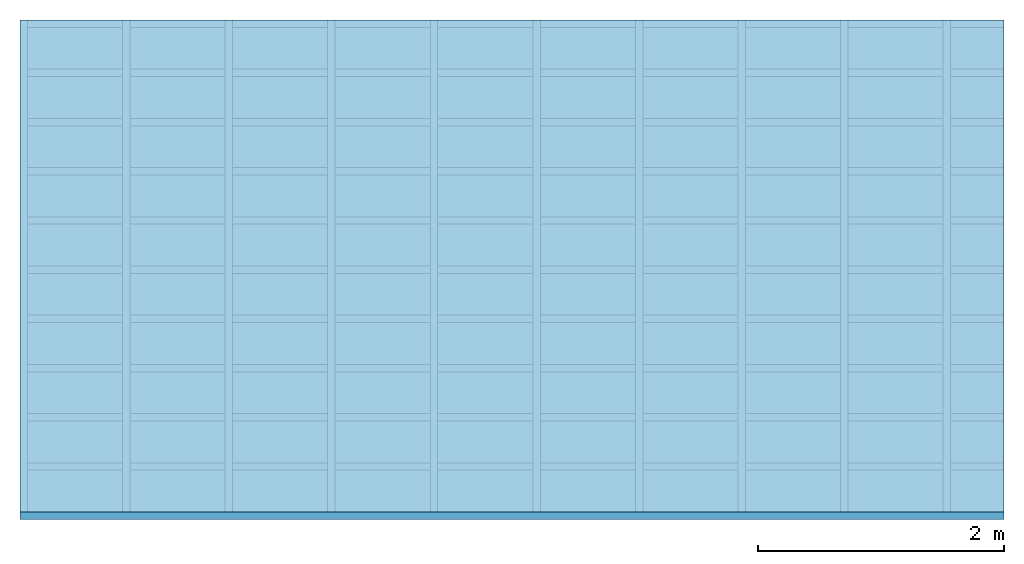
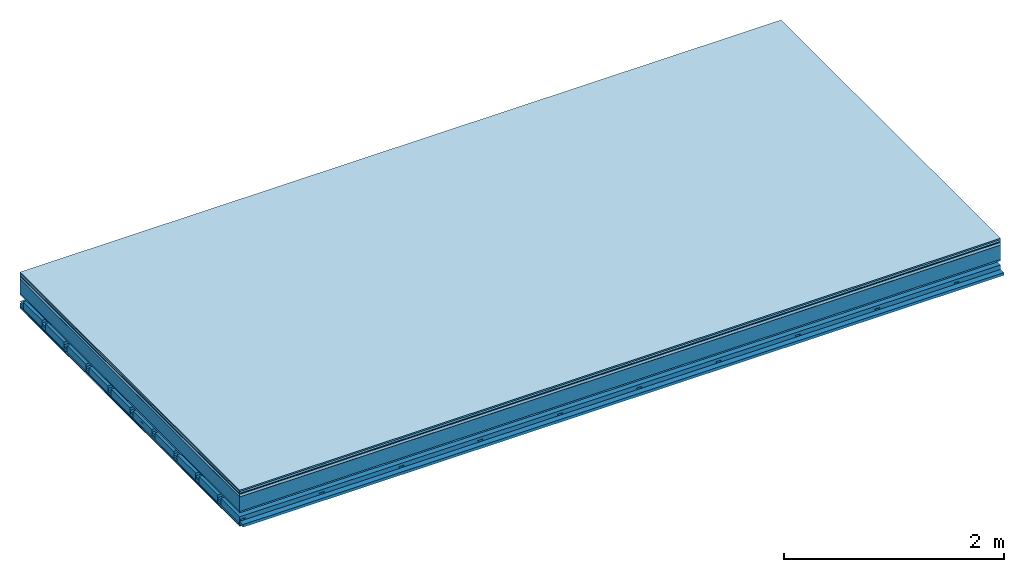
# One storey: 9 plates, 4 members, 1 element without a shape of its own.
"""IFC4 building model written with IfcOpenShell, lengths in metres."""

from ifc_helpers import new_model, si_unit, derived_unit, direction, frame, frame_2d, origin, origin_with_axes, place, context, project, spatial, polyline, rectangle, outline, extrude, material, layer, layer_set, type_object, element, aggregate, save


model = new_model("IFC4")

# Units and contexts
plan_context = context("Plan", 3, precision=1e-05, world=origin(), true_north=direction((0.0, 1.0)))
model_context = context("Model", 3, precision=1e-05, world=origin(), true_north=direction((0.0, 1.0)))
ifc_project = project(units=[si_unit("LENGTHUNIT", "METRE"), derived_unit("SOUNDPRESSUREUNIT", [(si_unit("PRESSUREUNIT", "PASCAL", prefix="MICRO"), 0)]), si_unit("ENERGYUNIT", "JOULE", prefix="MEGA"), si_unit("MASSUNIT", "GRAM", prefix="KILO"), derived_unit("THERMALTRANSMITTANCEUNIT", [(si_unit("POWERUNIT", "WATT"), 1), (si_unit("AREAUNIT", "SQUARE_METRE"), -1), (si_unit("THERMODYNAMICTEMPERATUREUNIT", "KELVIN"), -1)]), derived_unit("AREADENSITYUNIT", [(si_unit("MASSUNIT", "GRAM", prefix="KILO"), 1), (si_unit("AREAUNIT", "SQUARE_METRE"), -1)]), derived_unit("USERDEFINED", [(si_unit("ENERGYUNIT", "JOULE", prefix="MEGA"), 1), (si_unit("AREAUNIT", "SQUARE_METRE"), -1)])], contexts=[plan_context, model_context])

# Site, building, storey
site = spatial("IfcSite", under=ifc_project)
building_placement = place(None, origin())
building = spatial("IfcBuilding", under=site, at=building_placement)
storey_placement = place(building_placement, origin())
storey = spatial("IfcBuildingStorey", under=building, at=storey_placement)

# Slab, members, plates
ifc_material_1 = material(Category="11.013")
ifc_layer_1 = layer(ifc_material_1, 0.015, Name="Flooring")
ifc_material_2 = material(Category="03.007")
ifc_layer_2 = layer(ifc_material_2, 0.02, Name="On-material")
ifc_material_3 = material(Name="Wood fiber generic product", Category="10.009")
ifc_layer_3 = layer(ifc_material_3, 0.01, Name="Impact sound insulation")
ifc_material_4 = material(Name="with broken")
ifc_layer_4 = layer(ifc_material_4, 0.03, Name="on Supporting structure")
ifc_material_5 = material(Name="protection", Category="09.007")
ifc_layer_5 = layer(ifc_material_5, 0.0005, Name="Sub-floor")
ifc_material_6 = material(Name="no composite action")
ifc_layer_6 = layer(ifc_material_6, 0.0, Name="Bond")
ifc_layer_7 = layer(None, 0.16, Name="Supporting structure")
ifc_material_7 = material(Name="of the art")
ifc_layer_8 = layer(ifc_material_7, 0.0, Name="Bond")
ifc_layer_9 = layer(ifc_material_2, 0.015, Name="Lower layer 1")
ifc_layer_10 = layer(None, 0.095, Name="Coupling")
ifc_layer_11 = layer(None, 0.03, Name="Battens / profiles")
ifc_material_8 = material(Name="Plasterboard type A", Category="03.008")
ifc_layer_12 = layer(ifc_material_8, 0.0125, Name="Ceiling covering 1st layer")
ifc_layer_13 = layer(ifc_material_8, 0.0125, Name="Ceiling covering layer 2")
ifc_material_9 = material(Category="04.001")
ifc_layer_14 = layer(ifc_material_9, 0.003, Name="Surface / treatment")
ifc_layer_set = layer_set([ifc_layer_1, ifc_layer_2, ifc_layer_3, ifc_layer_4, ifc_layer_5, ifc_layer_6, ifc_layer_7, ifc_layer_8, ifc_layer_9, ifc_layer_10, ifc_layer_11, ifc_layer_12, ifc_layer_13, ifc_layer_14])
slab_type = type_object("IfcSlabType", Name="A2125", PredefinedType="NOTDEFINED", material=ifc_layer_set)
slab_placement = place(None, frame((0.0, 0.0, 0.0), z_axis=(0.0, 0.0, -1.0), x_axis=(1.0, 0.0, 0.0)))
slab = element("IfcSlab", 1, at=slab_placement, inside=storey, type_object=slab_type, material=ifc_layer_set, Name="Slab #1")
ifc_material_10 = material(Name="Solid timber panel")
member_1_placement = place(slab_placement, origin())
member_1 = element("IfcMember", 2, at=member_1_placement, material=ifc_material_10, Name="Supporting structure", context=plan_context, shape_type="SweptSolid", body=[
    extrude(rectangle(XDim=1.0, YDim=0.16, at=frame_2d((0.5, 0.08), x_axis=(1.0, 0.0))), frame((0.0, 4.0, 0.0755), z_axis=(0.0, -1.0, 0.0), x_axis=(1.0, 0.0, 0.0)), (0.0, 0.0, 1.0), 4.0),
    extrude(rectangle(XDim=1.0, YDim=0.16, at=frame_2d((0.5, 0.08), x_axis=(1.0, 0.0))), frame((1.0, 4.0, 0.0755), z_axis=(0.0, -1.0, 0.0), x_axis=(1.0, 0.0, 0.0)), (0.0, 0.0, 1.0), 4.0),
    extrude(rectangle(XDim=1.0, YDim=0.16, at=frame_2d((0.5, 0.08), x_axis=(1.0, 0.0))), frame((2.0, 4.0, 0.0755), z_axis=(0.0, -1.0, 0.0), x_axis=(1.0, 0.0, 0.0)), (0.0, 0.0, 1.0), 4.0),
    extrude(rectangle(XDim=1.0, YDim=0.16, at=frame_2d((0.5, 0.08), x_axis=(1.0, 0.0))), frame((3.0, 4.0, 0.0755), z_axis=(0.0, -1.0, 0.0), x_axis=(1.0, 0.0, 0.0)), (0.0, 0.0, 1.0), 4.0),
    extrude(rectangle(XDim=1.0, YDim=0.16, at=frame_2d((0.5, 0.08), x_axis=(1.0, 0.0))), frame((4.0, 4.0, 0.0755), z_axis=(0.0, -1.0, 0.0), x_axis=(1.0, 0.0, 0.0)), (0.0, 0.0, 1.0), 4.0),
    extrude(rectangle(XDim=1.0, YDim=0.16, at=frame_2d((0.5, 0.08), x_axis=(1.0, 0.0))), frame((5.0, 4.0, 0.0755), z_axis=(0.0, -1.0, 0.0), x_axis=(1.0, 0.0, 0.0)), (0.0, 0.0, 1.0), 4.0),
    extrude(rectangle(XDim=1.0, YDim=0.16, at=frame_2d((0.5, 0.08), x_axis=(1.0, 0.0))), frame((6.0, 4.0, 0.0755), z_axis=(0.0, -1.0, 0.0), x_axis=(1.0, 0.0, 0.0)), (0.0, 0.0, 1.0), 4.0),
    extrude(rectangle(XDim=1.0, YDim=0.16, at=frame_2d((0.5, 0.08), x_axis=(1.0, 0.0))), frame((7.0, 4.0, 0.0755), z_axis=(0.0, -1.0, 0.0), x_axis=(1.0, 0.0, 0.0)), (0.0, 0.0, 1.0), 4.0),
])
ifc_material_11 = material()
member_2_placement = place(slab_placement, origin())
member_2 = element("IfcMember", 3, at=member_2_placement, material=ifc_material_11, Name="Coupling", context=plan_context, shape_type="SweptSolid", body=[
    extrude(outline(polyline([(0.0, 0.0), (0.06, 0.0), (0.04, 0.02), (0.02, 0.02), (0.0, 0.0)])), frame((0.0, 4.0, 0.3255), z_axis=(0.0, -1.0, 0.0), x_axis=(1.0, 0.0, 0.0)), (0.0, 0.0, 1.0), 4.0),
    extrude(outline(polyline([(0.0, 0.0), (0.06, 0.0), (0.04, 0.02), (0.02, 0.02), (0.0, 0.0)])), frame((0.834, 4.0, 0.3255), z_axis=(0.0, -1.0, 0.0), x_axis=(1.0, 0.0, 0.0)), (0.0, 0.0, 1.0), 4.0),
    extrude(outline(polyline([(0.0, 0.0), (0.06, 0.0), (0.04, 0.02), (0.02, 0.02), (0.0, 0.0)])), frame((1.668, 4.0, 0.3255), z_axis=(0.0, -1.0, 0.0), x_axis=(1.0, 0.0, 0.0)), (0.0, 0.0, 1.0), 4.0),
    extrude(outline(polyline([(0.0, 0.0), (0.06, 0.0), (0.04, 0.02), (0.02, 0.02), (0.0, 0.0)])), frame((2.502, 4.0, 0.3255), z_axis=(0.0, -1.0, 0.0), x_axis=(1.0, 0.0, 0.0)), (0.0, 0.0, 1.0), 4.0),
    extrude(outline(polyline([(0.0, 0.0), (0.06, 0.0), (0.04, 0.02), (0.02, 0.02), (0.0, 0.0)])), frame((3.336, 4.0, 0.3255), z_axis=(0.0, -1.0, 0.0), x_axis=(1.0, 0.0, 0.0)), (0.0, 0.0, 1.0), 4.0),
    extrude(outline(polyline([(0.0, 0.0), (0.06, 0.0), (0.04, 0.02), (0.02, 0.02), (0.0, 0.0)])), frame((4.17, 4.0, 0.3255), z_axis=(0.0, -1.0, 0.0), x_axis=(1.0, 0.0, 0.0)), (0.0, 0.0, 1.0), 4.0),
    extrude(outline(polyline([(0.0, 0.0), (0.06, 0.0), (0.04, 0.02), (0.02, 0.02), (0.0, 0.0)])), frame((5.004, 4.0, 0.3255), z_axis=(0.0, -1.0, 0.0), x_axis=(1.0, 0.0, 0.0)), (0.0, 0.0, 1.0), 4.0),
    extrude(outline(polyline([(0.0, 0.0), (0.06, 0.0), (0.04, 0.02), (0.02, 0.02), (0.0, 0.0)])), frame((5.838, 4.0, 0.3255), z_axis=(0.0, -1.0, 0.0), x_axis=(1.0, 0.0, 0.0)), (0.0, 0.0, 1.0), 4.0),
    extrude(outline(polyline([(0.0, 0.0), (0.06, 0.0), (0.04, 0.02), (0.02, 0.02), (0.0, 0.0)])), frame((6.672, 4.0, 0.3255), z_axis=(0.0, -1.0, 0.0), x_axis=(1.0, 0.0, 0.0)), (0.0, 0.0, 1.0), 4.0),
    extrude(outline(polyline([(0.0, 0.0), (0.06, 0.0), (0.04, 0.02), (0.02, 0.02), (0.0, 0.0)])), frame((7.506, 4.0, 0.3255), z_axis=(0.0, -1.0, 0.0), x_axis=(1.0, 0.0, 0.0)), (0.0, 0.0, 1.0), 4.0),
])
member_3_placement = place(slab_placement, origin())
member_3 = element("IfcMember", 4, at=member_3_placement, material=ifc_material_11, Name="Battens / profiles", context=plan_context, shape_type="SweptSolid", body=[
    extrude(rectangle(XDim=0.06, YDim=0.03, at=frame_2d((0.03, 0.015), x_axis=(1.0, 0.0))), frame((0.0, 0.0, 0.3455), z_axis=(1.0, 0.0, 0.0), x_axis=(0.0, 1.0, 0.0)), (0.0, 0.0, 1.0), 8.0),
    extrude(rectangle(XDim=0.06, YDim=0.03, at=frame_2d((0.03, 0.015), x_axis=(1.0, 0.0))), frame((0.0, 0.4, 0.3455), z_axis=(1.0, 0.0, 0.0), x_axis=(0.0, 1.0, 0.0)), (0.0, 0.0, 1.0), 8.0),
    extrude(rectangle(XDim=0.06, YDim=0.03, at=frame_2d((0.03, 0.015), x_axis=(1.0, 0.0))), frame((0.0, 0.8, 0.3455), z_axis=(1.0, 0.0, 0.0), x_axis=(0.0, 1.0, 0.0)), (0.0, 0.0, 1.0), 8.0),
    extrude(rectangle(XDim=0.06, YDim=0.03, at=frame_2d((0.03, 0.015), x_axis=(1.0, 0.0))), frame((0.0, 1.2, 0.3455), z_axis=(1.0, 0.0, 0.0), x_axis=(0.0, 1.0, 0.0)), (0.0, 0.0, 1.0), 8.0),
    extrude(rectangle(XDim=0.06, YDim=0.03, at=frame_2d((0.03, 0.015), x_axis=(1.0, 0.0))), frame((0.0, 1.6, 0.3455), z_axis=(1.0, 0.0, 0.0), x_axis=(0.0, 1.0, 0.0)), (0.0, 0.0, 1.0), 8.0),
    extrude(rectangle(XDim=0.06, YDim=0.03, at=frame_2d((0.03, 0.015), x_axis=(1.0, 0.0))), frame((0.0, 2.0, 0.3455), z_axis=(1.0, 0.0, 0.0), x_axis=(0.0, 1.0, 0.0)), (0.0, 0.0, 1.0), 8.0),
    extrude(rectangle(XDim=0.06, YDim=0.03, at=frame_2d((0.03, 0.015), x_axis=(1.0, 0.0))), frame((0.0, 2.4, 0.3455), z_axis=(1.0, 0.0, 0.0), x_axis=(0.0, 1.0, 0.0)), (0.0, 0.0, 1.0), 8.0),
    extrude(rectangle(XDim=0.06, YDim=0.03, at=frame_2d((0.03, 0.015), x_axis=(1.0, 0.0))), frame((0.0, 2.8, 0.3455), z_axis=(1.0, 0.0, 0.0), x_axis=(0.0, 1.0, 0.0)), (0.0, 0.0, 1.0), 8.0),
    extrude(rectangle(XDim=0.06, YDim=0.03, at=frame_2d((0.03, 0.015), x_axis=(1.0, 0.0))), frame((0.0, 3.2, 0.3455), z_axis=(1.0, 0.0, 0.0), x_axis=(0.0, 1.0, 0.0)), (0.0, 0.0, 1.0), 8.0),
    extrude(rectangle(XDim=0.06, YDim=0.03, at=frame_2d((0.03, 0.015), x_axis=(1.0, 0.0))), frame((0.0, 3.6, 0.3455), z_axis=(1.0, 0.0, 0.0), x_axis=(0.0, 1.0, 0.0)), (0.0, 0.0, 1.0), 8.0),
    extrude(rectangle(XDim=0.06, YDim=0.03, at=frame_2d((0.03, 0.015), x_axis=(1.0, 0.0))), frame((0.0, 4.0, 0.3455), z_axis=(1.0, 0.0, 0.0), x_axis=(0.0, 1.0, 0.0)), (0.0, 0.0, 1.0), 8.0),
])
ifc_material_12 = material()
member_4_placement = place(slab_placement, origin())
member_4 = element("IfcMember", 5, at=member_4_placement, material=ifc_material_12, Name="Cavity", context=plan_context, shape_type="SweptSolid", body=[
    extrude(rectangle(XDim=0.34, YDim=0.08, at=frame_2d((0.17, 0.04), x_axis=(1.0, 0.0))), frame((0.0, 0.06, 0.2955), z_axis=(1.0, 0.0, 0.0), x_axis=(0.0, 1.0, 0.0)), (0.0, 0.0, 1.0), 8.0),
    extrude(rectangle(XDim=0.34, YDim=0.08, at=frame_2d((0.17, 0.04), x_axis=(1.0, 0.0))), frame((0.0, 0.46, 0.2955), z_axis=(1.0, 0.0, 0.0), x_axis=(0.0, 1.0, 0.0)), (0.0, 0.0, 1.0), 8.0),
    extrude(rectangle(XDim=0.34, YDim=0.08, at=frame_2d((0.17, 0.04), x_axis=(1.0, 0.0))), frame((0.0, 0.86, 0.2955), z_axis=(1.0, 0.0, 0.0), x_axis=(0.0, 1.0, 0.0)), (0.0, 0.0, 1.0), 8.0),
    extrude(rectangle(XDim=0.34, YDim=0.08, at=frame_2d((0.17, 0.04), x_axis=(1.0, 0.0))), frame((0.0, 1.26, 0.2955), z_axis=(1.0, 0.0, 0.0), x_axis=(0.0, 1.0, 0.0)), (0.0, 0.0, 1.0), 8.0),
    extrude(rectangle(XDim=0.34, YDim=0.08, at=frame_2d((0.17, 0.04), x_axis=(1.0, 0.0))), frame((0.0, 1.66, 0.2955), z_axis=(1.0, 0.0, 0.0), x_axis=(0.0, 1.0, 0.0)), (0.0, 0.0, 1.0), 8.0),
    extrude(rectangle(XDim=0.34, YDim=0.08, at=frame_2d((0.17, 0.04), x_axis=(1.0, 0.0))), frame((0.0, 2.06, 0.2955), z_axis=(1.0, 0.0, 0.0), x_axis=(0.0, 1.0, 0.0)), (0.0, 0.0, 1.0), 8.0),
    extrude(rectangle(XDim=0.34, YDim=0.08, at=frame_2d((0.17, 0.04), x_axis=(1.0, 0.0))), frame((0.0, 2.46, 0.2955), z_axis=(1.0, 0.0, 0.0), x_axis=(0.0, 1.0, 0.0)), (0.0, 0.0, 1.0), 8.0),
    extrude(rectangle(XDim=0.34, YDim=0.08, at=frame_2d((0.17, 0.04), x_axis=(1.0, 0.0))), frame((0.0, 2.86, 0.2955), z_axis=(1.0, 0.0, 0.0), x_axis=(0.0, 1.0, 0.0)), (0.0, 0.0, 1.0), 8.0),
    extrude(rectangle(XDim=0.34, YDim=0.08, at=frame_2d((0.17, 0.04), x_axis=(1.0, 0.0))), frame((0.0, 3.26, 0.2955), z_axis=(1.0, 0.0, 0.0), x_axis=(0.0, 1.0, 0.0)), (0.0, 0.0, 1.0), 8.0),
    extrude(rectangle(XDim=0.34, YDim=0.08, at=frame_2d((0.17, 0.04), x_axis=(1.0, 0.0))), frame((0.0, 3.66, 0.2955), z_axis=(1.0, 0.0, 0.0), x_axis=(0.0, 1.0, 0.0)), (0.0, 0.0, 1.0), 8.0),
])
plate_1_placement = place(slab_placement, origin())
plate_1 = element("IfcPlate", 6, at=plate_1_placement, material=ifc_material_1, Name="Flooring", context=plan_context, shape_type="SweptSolid", body=[
    extrude(rectangle(XDim=8.0, YDim=4.0, at=frame_2d((4.0, 2.0), x_axis=(1.0, 0.0))), origin_with_axes(), (0.0, 0.0, 1.0), 0.015),
])
plate_2_placement = place(slab_placement, origin())
plate_2 = element("IfcPlate", 7, at=plate_2_placement, material=ifc_material_2, Name="On-material", context=plan_context, shape_type="SweptSolid", body=[
    extrude(rectangle(XDim=8.0, YDim=4.0, at=frame_2d((4.0, 2.0), x_axis=(1.0, 0.0))), frame((0.0, 0.0, 0.015), z_axis=(0.0, 0.0, 1.0), x_axis=(1.0, 0.0, 0.0)), (0.0, 0.0, 1.0), 0.02),
])
plate_3_placement = place(slab_placement, origin())
plate_3 = element("IfcPlate", 8, at=plate_3_placement, material=ifc_material_3, Name="Impact sound insulation", context=plan_context, shape_type="SweptSolid", body=[
    extrude(rectangle(XDim=8.0, YDim=4.0, at=frame_2d((4.0, 2.0), x_axis=(1.0, 0.0))), frame((0.0, 0.0, 0.035), z_axis=(0.0, 0.0, 1.0), x_axis=(1.0, 0.0, 0.0)), (0.0, 0.0, 1.0), 0.01),
])
plate_4_placement = place(slab_placement, origin())
plate_4 = element("IfcPlate", 9, at=plate_4_placement, material=ifc_material_4, Name="on Supporting structure", context=plan_context, shape_type="SweptSolid", body=[
    extrude(rectangle(XDim=8.0, YDim=4.0, at=frame_2d((4.0, 2.0), x_axis=(1.0, 0.0))), frame((0.0, 0.0, 0.045), z_axis=(0.0, 0.0, 1.0), x_axis=(1.0, 0.0, 0.0)), (0.0, 0.0, 1.0), 0.03),
])
plate_5_placement = place(slab_placement, origin())
plate_5 = element("IfcPlate", 10, at=plate_5_placement, material=ifc_material_5, Name="Sub-floor", context=plan_context, shape_type="SweptSolid", body=[
    extrude(rectangle(XDim=8.0, YDim=4.0, at=frame_2d((4.0, 2.0), x_axis=(1.0, 0.0))), frame((0.0, 0.0, 0.075), z_axis=(0.0, 0.0, 1.0), x_axis=(1.0, 0.0, 0.0)), (0.0, 0.0, 1.0), 0.0005),
])
plate_6_placement = place(slab_placement, origin())
plate_6 = element("IfcPlate", 11, at=plate_6_placement, material=ifc_material_2, Name="Lower layer 1", context=plan_context, shape_type="SweptSolid", body=[
    extrude(rectangle(XDim=8.0, YDim=4.0, at=frame_2d((4.0, 2.0), x_axis=(1.0, 0.0))), frame((0.0, 0.0, 0.2355), z_axis=(0.0, 0.0, 1.0), x_axis=(1.0, 0.0, 0.0)), (0.0, 0.0, 1.0), 0.015),
])
plate_7_placement = place(slab_placement, origin())
plate_7 = element("IfcPlate", 12, at=plate_7_placement, material=ifc_material_8, Name="Ceiling covering 1st layer", context=plan_context, shape_type="SweptSolid", body=[
    extrude(rectangle(XDim=8.0, YDim=4.0, at=frame_2d((4.0, 2.0), x_axis=(1.0, 0.0))), frame((0.0, 0.0, 0.3755), z_axis=(0.0, 0.0, 1.0), x_axis=(1.0, 0.0, 0.0)), (0.0, 0.0, 1.0), 0.0125),
])
plate_8_placement = place(slab_placement, origin())
plate_8 = element("IfcPlate", 13, at=plate_8_placement, material=ifc_material_8, Name="Ceiling covering layer 2", context=plan_context, shape_type="SweptSolid", body=[
    extrude(rectangle(XDim=8.0, YDim=4.0, at=frame_2d((4.0, 2.0), x_axis=(1.0, 0.0))), frame((0.0, 0.0, 0.388), z_axis=(0.0, 0.0, 1.0), x_axis=(1.0, 0.0, 0.0)), (0.0, 0.0, 1.0), 0.0125),
])
plate_9_placement = place(slab_placement, origin())
plate_9 = element("IfcPlate", 14, at=plate_9_placement, material=ifc_material_9, Name="Surface / treatment", context=plan_context, shape_type="SweptSolid", body=[
    extrude(rectangle(XDim=8.0, YDim=4.0, at=frame_2d((4.0, 2.0), x_axis=(1.0, 0.0))), frame((0.0, 0.0, 0.4005), z_axis=(0.0, 0.0, 1.0), x_axis=(1.0, 0.0, 0.0)), (0.0, 0.0, 1.0), 0.003),
])
aggregate(slab, [plate_1, plate_2, plate_3, plate_4, plate_5, member_1, plate_6, member_2, member_3, member_4, plate_7, plate_8, plate_9])

save(model, "model.ifc")
